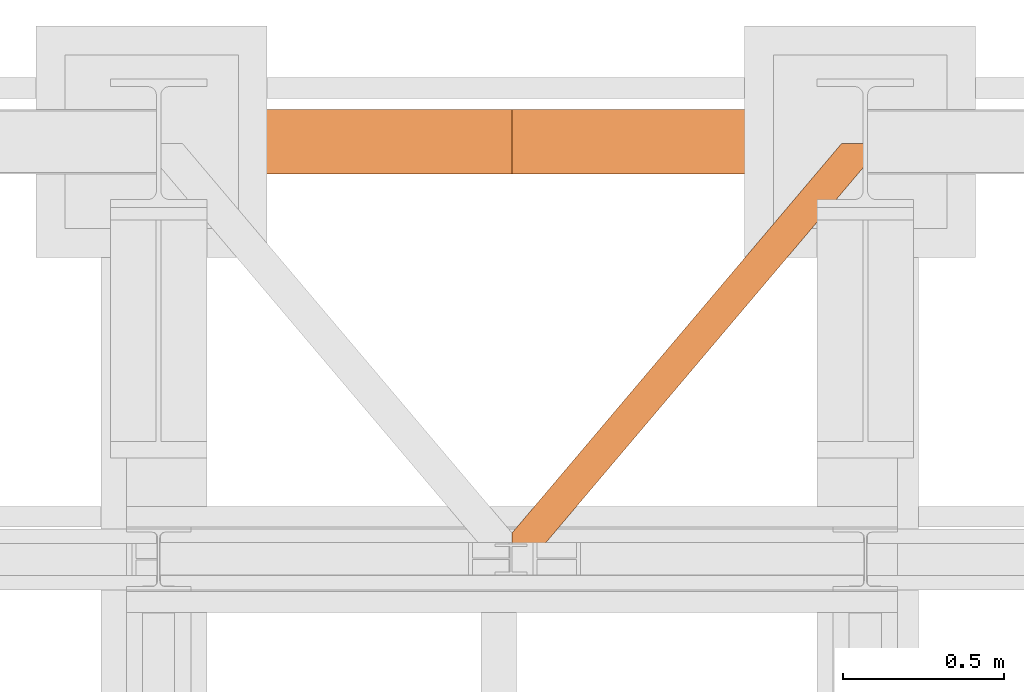
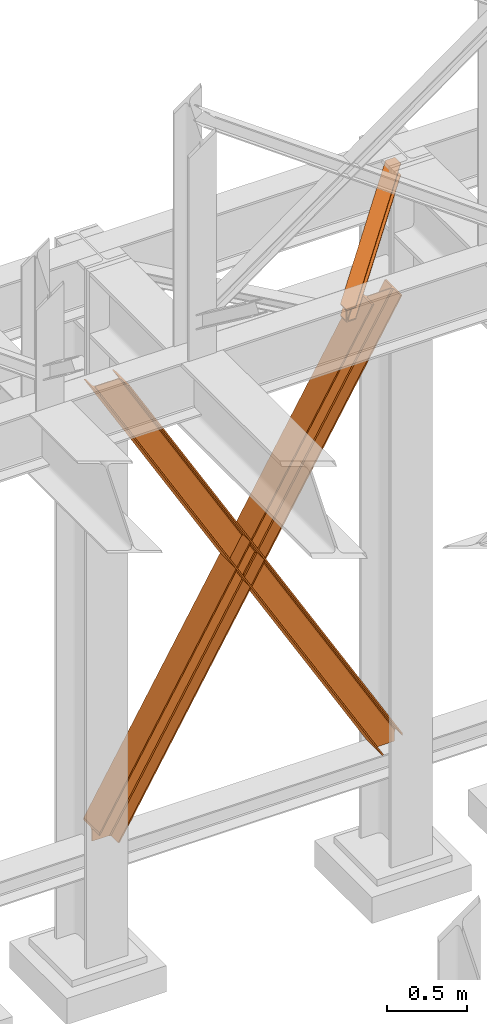
# One storey, part 140 of 208: 3 proxies.
"""IFC2X3 building model written with IfcOpenShell, lengths in millimetres."""

from ifc_helpers import new_model, entity, si_unit, converted_unit, frame, origin, origin_with_axes, place, context, subcontext, project, spatial, faceted_brep, element, save


model = new_model("IFC2X3")

# Units and contexts
model_context = context("Model", 3, precision=1e-05, world=origin())
plan_context = context("Plan", 3, precision=1e-05, world=origin())
body_context = subcontext(model_context, "Body", "Model", "MODEL_VIEW")
ifc_project = project(units=[si_unit("LENGTHUNIT", "METRE", prefix="MILLI"), converted_unit("PLANEANGLEUNIT", "DEGREE", entity("IfcPlaneAngleMeasure", 0.0174532925199433), si_unit("PLANEANGLEUNIT", "RADIAN"), dimensions=[0, 0, 0, 0, 0, 0, 0]), si_unit("AREAUNIT", "SQUARE_METRE"), si_unit("VOLUMEUNIT", "CUBIC_METRE")], contexts=[model_context, plan_context])

# Building, storey
building_placement = place(None, origin())
building = spatial("IfcBuilding", under=ifc_project, at=building_placement, CompositionType="COMPLEX")
storey_placement = place(building_placement, origin_with_axes())
storey = spatial("IfcBuildingStorey", under=building, at=storey_placement, Name="Geschoss", CompositionType="ELEMENT")

# Proxies
proxy_1_placement = place(storey_placement, frame((-0.1675494600947332, -12562.57439501764, 734.9900149335328), z_axis=(0.0, 0.0, 1.0), x_axis=(1.0, 0.0, 0.0)))
element("IfcBuildingElementProxy", 1, at=proxy_1_placement, inside=storey, context=body_context, shape_type="Brep", body=[
    faceted_brep([(2187.432517936612, 0.01000000000021828, 120.8497915510924), (216.8471928951319, 0.01000000000021828, 3468.009977913908), (216.8471928951319, 200.0100029802325, 3468.009977913908), (2187.432517936612, 200.0100029802325, 120.8497915510924), (2187.432517936612, 200.0100029802325, 120.8497915510924), (216.8471928951319, 200.0100029802325, 3468.009977913908), (205.4347121912165, 200.0100029802325, 3468.009977913908), (2187.432517936612, 200.0100029802325, 101.4682129393398), (2187.432517936612, 200.0100029802325, 101.4682129393398), (205.4347121912165, 200.0100029802325, 3468.009977913908), (205.4347036882539, 121.2600035762789, 3468.009977913908), (2187.432517936951, 121.2600035762789, 101.4681984983711), (2187.432517936951, 121.2600035762789, 101.4681984983711), (205.4347036882539, 121.2600035762789, 3468.009977913908), (203.3067948069668, 111.9441915473344, 3468.009977913909), (2187.432602958225, 111.9441915473344, 97.85427409430258), (2187.432602958225, 111.9441915473344, 97.85427409430258), (203.3067948069668, 111.9441915473344, 3468.009977913909), (195.5238886772497, 105.1245498640838, 3468.009977913908), (2187.432517936612, 105.1245498640838, 84.63689245399041), (2187.432517936612, 105.1245498640838, 84.63689245399041), (195.5238886772497, 105.1245498640838, 3468.009977913908), (184.892235020021, 103.2600015571716, 3468.009977913908), (2187.432517936612, 103.2600015571716, 66.58142866151923), (2187.432517936612, 103.2600015571716, 0.009999999999990905), (2187.432517936612, 103.2600015571716, 66.58142866151923), (184.892235020021, 103.2600015571716, 3468.009977913908), (31.96494937214834, 103.2600015571716, 3468.009977913908), (2073.723887154785, 103.2600015571716, 0.01000000000021828), (2073.723887154785, 103.2600015571716, 0.01000000000021828), (31.96494937214834, 103.2600015571716, 3468.009977913908), (21.3332957149189, 105.1245498640838, 3468.009977913908), (2063.093996904378, 105.1245498640838, 0.01000000000010459), (2063.093996904378, 105.1245498640838, 0.01000000000010459), (21.3332957149189, 105.1245498640838, 3468.009977913908), (13.55038958520231, 111.9441915473344, 3468.009977913908), (2055.312379673187, 111.9441915473344, 0.009999999999763531), (2055.312379673187, 111.9441915473344, 0.009999999999763531), (13.55038958520231, 111.9441915473344, 3468.009977913908), (11.42248070391565, 121.2600035762789, 3468.009977913907), (2053.184822892688, 121.2600035762789, 0.009999999999763531), (2053.184822892688, 121.2600035762789, 0.009999999999763531), (11.42248070391565, 121.2600035762789, 3468.009977913907), (11.42248070391611, 200.0100029802325, 3468.009977913907), (2053.184822892688, 200.0100029802325, 0.009999999999763531), (2053.184822892688, 200.0100029802325, 0.009999999999763531), (11.42248070391611, 200.0100029802325, 3468.009977913907), (0.009999999999990905, 200.0100029802325, 3468.009977913908), (2041.774228435658, 200.0100029802325, 0.009999999999990905), (2041.774228435658, 200.0100029802325, 0.009999999999990905), (0.009999999999990905, 200.0100029802325, 3468.009977913908), (0.009999999999990905, 0.01000000000021828, 3468.009977913908), (2041.774228435658, 0.01000000000021828, 0.009999999999990905), (2041.774228435658, 0.01000000000021828, 0.009999999999990905), (0.009999999999990905, 0.01000000000021828, 3468.009977913908), (11.42248070391656, 0.01000000000021828, 3468.009977913908), (2053.184822892688, 0.01000000000021828, 0.009999999999877218), (2053.184822892688, 0.01000000000021828, 0.009999999999877218), (11.42248070391656, 0.01000000000021828, 3468.009977913908), (11.42248070391611, 78.75999940395377, 3468.009977913907), (2053.184822892688, 78.75999940395377, 0.009999999999763531), (2053.184822892688, 78.75999940395377, 0.009999999999763531), (11.42248070391611, 78.75999940395377, 3468.009977913907), (13.55038958520231, 88.07581143290008, 3468.009977913908), (2055.312379673187, 88.07581143289826, 0.009999999999763531), (2055.312379673187, 88.07581143289826, 0.009999999999763531), (13.55038958520231, 88.07581143290008, 3468.009977913908), (21.3332957149189, 94.89545311614893, 3468.009977913908), (2063.093996904378, 94.89545311614893, 0.009999999999763531), (2063.093996904378, 94.89545311614893, 0.009999999999763531), (21.3332957149189, 94.89545311614893, 3468.009977913908), (31.96494937214834, 96.76000142306111, 3468.009977913908), (2073.723887154785, 96.76000142306111, 0.01000000000021828), (2073.723887154785, 96.76000142306111, 0.01000000000021828), (31.96494937214834, 96.76000142306111, 3468.009977913908), (184.892235020021, 96.76000142306111, 3468.009977913908), (2187.432517936612, 96.76000142306111, 66.58142866151888), (2187.432517936612, 96.76000142306111, 0.009999999999990905), (2187.432517936612, 96.76000142306111, 66.58142866151888), (184.892235020021, 96.76000142306111, 3468.009977913908), (195.5238886772497, 94.89545311614893, 3468.009977913908), (2187.432517936612, 94.89545311615075, 84.63689245399041), (2187.432517936612, 94.89545311615075, 84.63689245399041), (195.5238886772497, 94.89545311614893, 3468.009977913908), (203.3067948069668, 88.07581143289826, 3468.009977913909), (2187.432517936612, 88.07581143289826, 97.85441850857092), (2187.432517936612, 88.07581143289826, 97.85441850857092), (203.3067948069668, 88.07581143289826, 3468.009977913909), (205.4347036882541, 78.75999940395377, 3468.009977913908), (2187.432433072335, 78.75999940395377, 101.4683426459951), (2187.432433072335, 78.75999940395377, 101.4683426459951), (205.4347036882541, 78.75999940395377, 3468.009977913908), (205.4347121912165, 0.01000000000021828, 3468.009977913908), (2187.432517936272, 0.01000000000021828, 101.4682129399164), (2187.432517936272, 0.01000000000021828, 101.4682129399164), (205.4347121912165, 0.01000000000021828, 3468.009977913908), (216.8471928951319, 0.01000000000021828, 3468.009977913908), (2187.432517936612, 0.01000000000021828, 120.8497915510924), (216.8471928951319, 0.01000000000021828, 3468.009977913908), (205.4347121912165, 0.01000000000021828, 3468.009977913908), (205.4347036882541, 78.75999940395377, 3468.009977913908), (203.3067948069668, 88.07581143289826, 3468.009977913909), (195.5238886772497, 94.89545311614893, 3468.009977913908), (184.892235020021, 96.76000142306111, 3468.009977913908), (31.96494937214834, 96.76000142306111, 3468.009977913908), (21.3332957149189, 94.89545311614893, 3468.009977913908), (13.55038958520231, 88.07581143290008, 3468.009977913908), (11.42248070391611, 78.75999940395377, 3468.009977913907), (11.42248070391656, 0.01000000000021828, 3468.009977913908), (0.009999999999990905, 0.01000000000021828, 3468.009977913908), (0.009999999999990905, 200.0100029802325, 3468.009977913908), (11.42248070391611, 200.0100029802325, 3468.009977913907), (11.42248070391565, 121.2600035762789, 3468.009977913907), (13.55038958520231, 111.9441915473344, 3468.009977913908), (21.3332957149189, 105.1245498640838, 3468.009977913908), (31.96494937214834, 103.2600015571716, 3468.009977913908), (184.892235020021, 103.2600015571716, 3468.009977913908), (195.5238886772497, 105.1245498640838, 3468.009977913908), (203.3067948069668, 111.9441915473344, 3468.009977913909), (205.4347036882539, 121.2600035762789, 3468.009977913908), (205.4347121912165, 200.0100029802325, 3468.009977913908), (216.8471928951319, 200.0100029802325, 3468.009977913908), (2187.432517936612, 96.76000142306111, 0.009999999999990905), (2187.432517936612, 96.76000142306111, 66.58142866151888), (2187.432517936612, 94.89545311615075, 84.63689245399041), (2187.432517936612, 88.07581143289826, 97.85441850857092), (2187.432433072335, 78.75999940395377, 101.4683426459951), (2187.432517936272, 0.01000000000021828, 101.4682129399164), (2187.432517936612, 0.01000000000021828, 120.8497915510924), (2187.432517936612, 200.0100029802325, 120.8497915510924), (2187.432517936612, 200.0100029802325, 101.4682129393398), (2187.432517936951, 121.2600035762789, 101.4681984983711), (2187.432602958225, 111.9441915473344, 97.85427409430258), (2187.432517936612, 105.1245498640838, 84.63689245399041), (2187.432517936612, 103.2600015571716, 66.58142866151923), (2187.432517936612, 103.2600015571716, 0.009999999999990905), (2073.723887154785, 103.2600015571716, 0.01000000000021828), (2063.093996904378, 105.1245498640838, 0.01000000000010459), (2055.312379673187, 111.9441915473344, 0.009999999999763531), (2053.184822892688, 121.2600035762789, 0.009999999999763531), (2053.184822892688, 200.0100029802325, 0.009999999999763531), (2041.774228435658, 200.0100029802325, 0.009999999999990905), (2041.774228435658, 0.01000000000021828, 0.009999999999990905), (2053.184822892688, 0.01000000000021828, 0.009999999999877218), (2053.184822892688, 78.75999940395377, 0.009999999999763531), (2055.312379673187, 88.07581143289826, 0.009999999999763531), (2063.093996904378, 94.89545311614893, 0.009999999999763531), (2073.723887154785, 96.76000142306111, 0.01000000000021828), (2187.432517936612, 96.76000142306111, 0.009999999999990905), (2187.432517936612, 103.2600015571716, 0.009999999999990905)], [[[0, 1, 2, 3]], [[4, 5, 6, 7]], [[8, 9, 10, 11]], [[12, 13, 14, 15]], [[16, 17, 18, 19]], [[20, 21, 22, 23]], [[24, 25, 26, 27, 28]], [[29, 30, 31, 32]], [[33, 34, 35, 36]], [[37, 38, 39, 40]], [[41, 42, 43, 44]], [[45, 46, 47, 48]], [[49, 50, 51, 52]], [[53, 54, 55, 56]], [[57, 58, 59, 60]], [[61, 62, 63, 64]], [[65, 66, 67, 68]], [[69, 70, 71, 72]], [[73, 74, 75, 76, 77]], [[78, 79, 80, 81]], [[82, 83, 84, 85]], [[86, 87, 88, 89]], [[90, 91, 92, 93]], [[94, 95, 96, 97]], [[98, 99, 100, 101, 102, 103, 104, 105, 106, 107, 108, 109, 110, 111, 112, 113, 114, 115, 116, 117, 118, 119, 120, 121]], [[122, 123, 124, 125, 126, 127, 128, 129, 130, 131, 132, 133, 134, 135]], [[136, 137, 138, 139, 140, 141, 142, 143, 144, 145, 146, 147, 148, 149]]], orient=[[False], [False], [False], [False], [False], [False], [False], [False], [False], [False], [False], [False], [False], [False], [False], [False], [False], [False], [False], [False], [False], [False], [False], [False], [False], [False], [False]]),
])
proxy_2_placement = place(storey_placement, frame((-0.7451164407873421, -12562.57439501764, 734.9900149335328), z_axis=(0.0, 0.0, 1.0), x_axis=(1.0, 0.0, 0.0)))
element("IfcBuildingElementProxy", 2, at=proxy_2_placement, inside=storey, context=body_context, shape_type="Brep", body=[
    faceted_brep([(0.0100850216138042, 0.01000000000021828, 120.8497915510924), (0.0100850216138042, 200.0100029802325, 120.8497915510924), (1970.595410063094, 200.0100029802325, 3468.009977913908), (1970.595410063094, 0.01000000000021828, 3468.009977913908), (0.0100850216138042, 200.0100029802325, 120.8497915510924), (0.01008502161334945, 200.0100029802325, 101.4682129393398), (1982.007890767009, 200.0100029802325, 3468.009977913908), (1970.595410063094, 200.0100029802325, 3468.009977913908), (0.01008502161334945, 200.0100029802325, 101.4682129393398), (0.01008502127456268, 121.2600035762789, 101.4681984983711), (1982.007899269972, 121.2600035762789, 3468.009977913908), (1982.007890767009, 200.0100029802325, 3468.009977913908), (0.01008502127456268, 121.2600035762789, 101.4681984983711), (0.009999999999990905, 111.9441915473344, 97.85427409430258), (1984.135808151259, 111.9441915473344, 3468.009977913909), (1982.007899269972, 121.2600035762789, 3468.009977913908), (0.009999999999990905, 111.9441915473344, 97.85427409430258), (0.0100850216138042, 105.1245498640838, 84.63689245399041), (1991.918714280976, 105.1245498640838, 3468.009977913908), (1984.135808151259, 111.9441915473344, 3468.009977913909), (0.0100850216138042, 105.1245498640838, 84.63689245399041), (0.0100850216138042, 103.2600015571716, 66.58142866151923), (2002.550367938205, 103.2600015571716, 3468.009977913908), (1991.918714280976, 105.1245498640838, 3468.009977913908), (0.0100850216138042, 103.2600015571716, 0.009999999999990905), (113.7187158034401, 103.2600015571716, 0.01000000000021828), (2155.477653586077, 103.2600015571716, 3468.009977913908), (2002.550367938205, 103.2600015571716, 3468.009977913908), (0.0100850216138042, 103.2600015571716, 66.58142866151923), (113.7187158034401, 103.2600015571716, 0.01000000000021828), (124.3486060538469, 105.1245498640838, 0.01000000000010459), (2166.109307243306, 105.1245498640838, 3468.009977913908), (2155.477653586077, 103.2600015571716, 3468.009977913908), (124.3486060538469, 105.1245498640838, 0.01000000000010459), (132.1302232850383, 111.9441915473344, 0.009999999999763531), (2173.892213373023, 111.9441915473344, 3468.009977913908), (2166.109307243306, 105.1245498640838, 3468.009977913908), (132.1302232850383, 111.9441915473344, 0.009999999999763531), (134.257780065537, 121.2600035762789, 0.009999999999763531), (2176.020122254309, 121.2600035762789, 3468.009977913907), (2173.892213373023, 111.9441915473344, 3468.009977913908), (134.257780065537, 121.2600035762789, 0.009999999999763531), (134.257780065537, 200.0100029802325, 0.009999999999763531), (2176.020122254309, 200.0100029802325, 3468.009977913907), (2176.020122254309, 121.2600035762789, 3468.009977913907), (134.257780065537, 200.0100029802325, 0.009999999999763531), (145.6683745225666, 200.0100029802325, 0.009999999999990905), (2187.432602958225, 200.0100029802325, 3468.009977913908), (2176.020122254309, 200.0100029802325, 3468.009977913907), (145.6683745225666, 200.0100029802325, 0.009999999999990905), (145.6683745225666, 0.01000000000021828, 0.009999999999990905), (2187.432602958225, 0.01000000000021828, 3468.009977913908), (2187.432602958225, 200.0100029802325, 3468.009977913908), (145.6683745225666, 0.01000000000021828, 0.009999999999990905), (134.257780065537, 0.01000000000021828, 0.009999999999877218), (2176.020122254308, 0.01000000000021828, 3468.009977913908), (2187.432602958225, 0.01000000000021828, 3468.009977913908), (134.257780065537, 0.01000000000021828, 0.009999999999877218), (134.257780065537, 78.75999940395377, 0.009999999999763531), (2176.020122254309, 78.75999940395377, 3468.009977913907), (2176.020122254308, 0.01000000000021828, 3468.009977913908), (134.257780065537, 78.75999940395377, 0.009999999999763531), (132.1302232850383, 88.07581143289826, 0.009999999999763531), (2173.892213373023, 88.07581143290008, 3468.009977913908), (2176.020122254309, 78.75999940395377, 3468.009977913907), (132.1302232850383, 88.07581143289826, 0.009999999999763531), (124.3486060538464, 94.89545311614893, 0.009999999999763531), (2166.109307243306, 94.89545311614893, 3468.009977913908), (2173.892213373023, 88.07581143290008, 3468.009977913908), (124.3486060538464, 94.89545311614893, 0.009999999999763531), (113.7187158034401, 96.76000142306111, 0.01000000000021828), (2155.477653586077, 96.76000142306111, 3468.009977913908), (2166.109307243306, 94.89545311614893, 3468.009977913908), (113.7187158034401, 96.76000142306111, 0.01000000000021828), (0.01008502161334945, 96.76000142306111, 0.009999999999990905), (0.0100850216138042, 96.76000142306111, 66.58142866151888), (2002.550367938205, 96.76000142306111, 3468.009977913908), (2155.477653586077, 96.76000142306111, 3468.009977913908), (0.0100850216138042, 96.76000142306111, 66.58142866151888), (0.0100850216138042, 94.89545311615075, 84.63689245399041), (1991.918714280976, 94.89545311614893, 3468.009977913908), (2002.550367938205, 96.76000142306111, 3468.009977913908), (0.0100850216138042, 94.89545311615075, 84.63689245399041), (0.0100850216138042, 88.07581143289826, 97.85441850857092), (1984.135808151259, 88.07581143289826, 3468.009977913909), (1991.918714280976, 94.89545311614893, 3468.009977913908), (0.0100850216138042, 88.07581143289826, 97.85441850857092), (0.01016988589049106, 78.75999940395377, 101.4683426459951), (1982.007899269971, 78.75999940395377, 3468.009977913908), (1984.135808151259, 88.07581143289826, 3468.009977913909), (0.01016988589049106, 78.75999940395377, 101.4683426459951), (0.01008502195304573, 0.01000000000021828, 101.4682129399164), (1982.007890767009, 0.01000000000021828, 3468.009977913908), (1982.007899269971, 78.75999940395377, 3468.009977913908), (0.01008502195304573, 0.01000000000021828, 101.4682129399164), (0.0100850216138042, 0.01000000000021828, 120.8497915510924), (1970.595410063094, 0.01000000000021828, 3468.009977913908), (1982.007890767009, 0.01000000000021828, 3468.009977913908), (1970.595410063094, 0.01000000000021828, 3468.009977913908), (1970.595410063094, 200.0100029802325, 3468.009977913908), (1982.007890767009, 200.0100029802325, 3468.009977913908), (1982.007899269972, 121.2600035762789, 3468.009977913908), (1984.135808151259, 111.9441915473344, 3468.009977913909), (1991.918714280976, 105.1245498640838, 3468.009977913908), (2002.550367938205, 103.2600015571716, 3468.009977913908), (2155.477653586077, 103.2600015571716, 3468.009977913908), (2166.109307243306, 105.1245498640838, 3468.009977913908), (2173.892213373023, 111.9441915473344, 3468.009977913908), (2176.020122254309, 121.2600035762789, 3468.009977913907), (2176.020122254309, 200.0100029802325, 3468.009977913907), (2187.432602958225, 200.0100029802325, 3468.009977913908), (2187.432602958225, 0.01000000000021828, 3468.009977913908), (2176.020122254308, 0.01000000000021828, 3468.009977913908), (2176.020122254309, 78.75999940395377, 3468.009977913907), (2173.892213373023, 88.07581143290008, 3468.009977913908), (2166.109307243306, 94.89545311614893, 3468.009977913908), (2155.477653586077, 96.76000142306111, 3468.009977913908), (2002.550367938205, 96.76000142306111, 3468.009977913908), (1991.918714280976, 94.89545311614893, 3468.009977913908), (1984.135808151259, 88.07581143289826, 3468.009977913909), (1982.007899269971, 78.75999940395377, 3468.009977913908), (1982.007890767009, 0.01000000000021828, 3468.009977913908), (0.01008502161334945, 96.76000142306111, 0.009999999999990905), (0.0100850216138042, 103.2600015571716, 0.009999999999990905), (0.0100850216138042, 103.2600015571716, 66.58142866151923), (0.0100850216138042, 105.1245498640838, 84.63689245399041), (0.009999999999990905, 111.9441915473344, 97.85427409430258), (0.01008502127456268, 121.2600035762789, 101.4681984983711), (0.01008502161334945, 200.0100029802325, 101.4682129393398), (0.0100850216138042, 200.0100029802325, 120.8497915510924), (0.0100850216138042, 0.01000000000021828, 120.8497915510924), (0.01008502195304573, 0.01000000000021828, 101.4682129399164), (0.01016988589049106, 78.75999940395377, 101.4683426459951), (0.0100850216138042, 88.07581143289826, 97.85441850857092), (0.0100850216138042, 94.89545311615075, 84.63689245399041), (0.0100850216138042, 96.76000142306111, 66.58142866151888), (113.7187158034401, 103.2600015571716, 0.01000000000021828), (0.0100850216138042, 103.2600015571716, 0.009999999999990905), (0.01008502161334945, 96.76000142306111, 0.009999999999990905), (113.7187158034401, 96.76000142306111, 0.01000000000021828), (124.3486060538464, 94.89545311614893, 0.009999999999763531), (132.1302232850383, 88.07581143289826, 0.009999999999763531), (134.257780065537, 78.75999940395377, 0.009999999999763531), (134.257780065537, 0.01000000000021828, 0.009999999999877218), (145.6683745225666, 0.01000000000021828, 0.009999999999990905), (145.6683745225666, 200.0100029802325, 0.009999999999990905), (134.257780065537, 200.0100029802325, 0.009999999999763531), (134.257780065537, 121.2600035762789, 0.009999999999763531), (132.1302232850383, 111.9441915473344, 0.009999999999763531), (124.3486060538469, 105.1245498640838, 0.01000000000010459)], [[[0, 1, 2, 3]], [[4, 5, 6, 7]], [[8, 9, 10, 11]], [[12, 13, 14, 15]], [[16, 17, 18, 19]], [[20, 21, 22, 23]], [[24, 25, 26, 27, 28]], [[29, 30, 31, 32]], [[33, 34, 35, 36]], [[37, 38, 39, 40]], [[41, 42, 43, 44]], [[45, 46, 47, 48]], [[49, 50, 51, 52]], [[53, 54, 55, 56]], [[57, 58, 59, 60]], [[61, 62, 63, 64]], [[65, 66, 67, 68]], [[69, 70, 71, 72]], [[73, 74, 75, 76, 77]], [[78, 79, 80, 81]], [[82, 83, 84, 85]], [[86, 87, 88, 89]], [[90, 91, 92, 93]], [[94, 95, 96, 97]], [[98, 99, 100, 101, 102, 103, 104, 105, 106, 107, 108, 109, 110, 111, 112, 113, 114, 115, 116, 117, 118, 119, 120, 121]], [[122, 123, 124, 125, 126, 127, 128, 129, 130, 131, 132, 133, 134, 135]], [[136, 137, 138, 139, 140, 141, 142, 143, 144, 145, 146, 147, 148, 149]]], orient=[[False], [False], [False], [False], [False], [False], [False], [False], [False], [False], [False], [False], [False], [False], [False], [False], [False], [False], [False], [False], [False], [False], [False], [False], [False], [False], [False]]),
])
proxy_3_placement = place(storey_placement, frame((1093.254968528672, -13757.87439038569, 5101.99001616488), z_axis=(0.0, 0.0, 1.0), x_axis=(1.0, 0.0, 0.0)))
element("IfcBuildingElementProxy", 3, at=proxy_3_placement, inside=storey, context=body_context, shape_type="Brep", body=[
    faceted_brep([(65.50764084493926, 0.00999999999839929, 8.010001311303313), (1094.009999947835, 1215.512788030694, 8.010001311302403), (1094.009999947835, 1215.512788030694, 0.01000000000112777), (65.50764084493926, 0.00999999999839929, 0.01000000000112777), (65.50764084493926, 0.00999999999839929, 0.01000000000112777), (1094.009999947835, 1215.512788030694, 0.01000000000112777), (1094.009999947835, 1290.610003345229, 0.01000000000021828), (1026.558515831797, 1290.610003345229, 0.01000000000021828), (0.01000000000271939, 77.41630281674588, 0.01000000000112777), (0.01000000000271939, 0.00999999999839929, 0.01000000000112777), (0.01000000000271939, 77.41630281674588, 0.01000000000112777), (1026.558515831797, 1290.610003345229, 0.01000000000021828), (1026.558515831797, 1290.610003345229, 8.010001311303313), (0.0100000000009004, 77.41630281674406, 8.010001311303313), (0.0100000000009004, 77.41630281674406, 8.010001311303313), (1026.558515831797, 1290.610003345229, 8.010001311303313), (1073.061840441307, 1290.610003345229, 8.010001311303313), (0.01000000000271939, 22.45782827823314, 8.010001311303313), (0.01000000000271939, 22.45782827823314, 8.010001311303313), (1073.061840441307, 1290.610003345229, 8.010001311303313), (1081.197355239432, 1290.610003345229, 9.253033826352294), (0.01000000000180989, 12.84312897135897, 9.253033826352294), (0.01000000000180989, 12.84312897135897, 9.253033826352294), (1081.197355239432, 1290.610003345229, 9.253033826352294), (1087.152961141162, 1290.610003345229, 13.79946006298178), (0.01000000000180989, 5.804685632949258, 13.79946006298178), (0.01000000000180989, 5.804685632949258, 13.79946006298178), (1087.152961141162, 1290.610003345229, 13.79946006298178), (1088.781274451488, 1290.610003345229, 20.01000141561144), (0.01000000000271939, 3.880315357109794, 20.01000141561144), (0.01000000000271939, 3.880315357109794, 20.01000141561144), (1088.781274451488, 1290.610003345229, 20.01000141561144), (1088.781274451488, 1290.610003345229, 76.01000128150099), (0.01000000000271939, 3.880315357109794, 76.01000128150099), (0.01000000000271939, 3.880315357109794, 76.01000128150099), (1088.781274451488, 1290.610003345229, 76.01000128150099), (1087.152961141161, 1290.610003345229, 82.2205407714855), (0.01000000000180989, 5.804685632949258, 82.2205407714855), (0.01000000000180989, 5.804685632949258, 82.2205407714855), (1087.152961141161, 1290.610003345229, 82.2205407714855), (1081.197355239431, 1290.610003345229, 86.76696700811499), (0.01000000000180989, 12.84312897135897, 86.76696700811499), (0.01000000000180989, 12.84312897135897, 86.76696700811499), (1081.197355239431, 1290.610003345229, 86.76696700811499), (1073.061840441306, 1290.610003345229, 88.00999952316397), (0.01000000000180989, 22.45782827823314, 88.00999952316397), (0.01000000000180989, 22.45782827823314, 88.00999952316397), (1073.061840441306, 1290.610003345229, 88.00999952316397), (1026.558515831797, 1290.610003345229, 88.00999952316397), (0.01000000000271939, 77.41630281674588, 88.00999952316397), (0.01000000000271939, 77.41630281674588, 88.00999952316397), (1026.558515831797, 1290.610003345229, 88.00999952316397), (1026.558515831797, 1290.610003345229, 96.01000083446615), (0.009999999999990905, 77.41630281674406, 96.01000083446615), (0.009999999999990905, 77.41630281674406, 96.01000083446615), (1026.558515831797, 1290.610003345229, 96.01000083446615), (1094.009999947835, 1290.610003345229, 96.01000083446615), (1094.009999947835, 1215.512788030694, 96.01000083446615), (65.50764084493835, 0.00999999999839929, 96.01000083446615), (0.0100000000009004, 0.00999999999839929, 96.01000083446615), (65.50764084493835, 0.00999999999839929, 96.01000083446615), (1094.009999947835, 1215.512788030694, 96.01000083446615), (1094.009999947835, 1215.512788030694, 88.00999952316397), (65.50764084493835, 0.00999999999839929, 88.00999952316397), (65.50764084493835, 0.00999999999839929, 88.00999952316397), (1094.009999947835, 1215.512788030694, 88.00999952316397), (1094.009999947835, 1270.471262569206, 88.00999952316397), (19.0043162354275, 0.00999999999839929, 88.00999952316397), (19.0043162354275, 0.00999999999839929, 88.00999952316397), (1094.009999947835, 1270.471262569206, 88.00999952316397), (1094.009999947835, 1280.085961876082, 86.76696700811499), (10.86880143730173, 0.00999999999839929, 86.76696700811499), (10.86880143730173, 0.00999999999839929, 86.76696700811499), (1094.009999947835, 1280.085961876082, 86.76696700811499), (1094.009999947835, 1287.124405214488, 82.2205407714855), (4.913195535572186, 0.00999999999839929, 82.2205407714855), (4.913195535572186, 0.00999999999839929, 82.2205407714855), (1094.009999947835, 1287.124405214488, 82.2205407714855), (1094.009999947834, 1289.048775490332, 76.01000128150099), (3.284882225245156, 0.00999999999839929, 76.01000128150099), (3.284882225245156, 0.00999999999839929, 76.01000128150099), (1094.009999947834, 1289.048775490332, 76.01000128150099), (1094.009999947835, 1289.048775490332, 20.01000141561144), (3.284882225246065, 0.00999999999839929, 20.01000141561144), (3.284882225246065, 0.00999999999839929, 20.01000141561144), (1094.009999947835, 1289.048775490332, 20.01000141561144), (1094.009999947835, 1287.12440521449, 13.79946006298178), (4.913195535572186, 0.00999999999839929, 13.79946006298178), (4.913195535572186, 0.00999999999839929, 13.79946006298178), (1094.009999947835, 1287.12440521449, 13.79946006298178), (1094.009999947835, 1280.085961876081, 9.253033826352294), (10.86880143730264, 0.00999999999839929, 9.253033826352294), (10.86880143730264, 0.00999999999839929, 9.253033826352294), (1094.009999947835, 1280.085961876081, 9.253033826352294), (1094.009999947835, 1270.471262569206, 8.010001311303313), (19.00431623542931, 0.00999999999839929, 8.010001311303313), (19.00431623542931, 0.00999999999839929, 8.010001311303313), (1094.009999947835, 1270.471262569206, 8.010001311303313), (1094.009999947835, 1215.512788030694, 8.010001311302403), (65.50764084493926, 0.00999999999839929, 8.010001311303313), (0.01000000000271939, 77.41630281674588, 0.01000000000112777), (0.0100000000009004, 77.41630281674406, 8.010001311303313), (0.01000000000271939, 22.45782827823314, 8.010001311303313), (0.01000000000180989, 12.84312897135897, 9.253033826352294), (0.01000000000180989, 5.804685632949258, 13.79946006298178), (0.01000000000271939, 3.880315357109794, 20.01000141561144), (0.01000000000271939, 3.880315357109794, 76.01000128150099), (0.01000000000180989, 5.804685632949258, 82.2205407714855), (0.01000000000180989, 12.84312897135897, 86.76696700811499), (0.01000000000180989, 22.45782827823314, 88.00999952316397), (0.01000000000271939, 77.41630281674588, 88.00999952316397), (0.009999999999990905, 77.41630281674406, 96.01000083446615), (0.0100000000009004, 0.00999999999839929, 96.01000083446615), (0.01000000000271939, 0.00999999999839929, 0.01000000000112777), (0.0100000000009004, 0.00999999999839929, 96.01000083446615), (65.50764084493835, 0.00999999999839929, 96.01000083446615), (65.50764084493835, 0.00999999999839929, 88.00999952316397), (19.0043162354275, 0.00999999999839929, 88.00999952316397), (10.86880143730173, 0.00999999999839929, 86.76696700811499), (4.913195535572186, 0.00999999999839929, 82.2205407714855), (3.284882225245156, 0.00999999999839929, 76.01000128150099), (3.284882225246065, 0.00999999999839929, 20.01000141561144), (4.913195535572186, 0.00999999999839929, 13.79946006298178), (10.86880143730264, 0.00999999999839929, 9.253033826352294), (19.00431623542931, 0.00999999999839929, 8.010001311303313), (65.50764084493926, 0.00999999999839929, 8.010001311303313), (65.50764084493926, 0.00999999999839929, 0.01000000000112777), (0.01000000000271939, 0.00999999999839929, 0.01000000000112777), (1094.009999947835, 1215.512788030694, 8.010001311302403), (1094.009999947835, 1270.471262569206, 8.010001311303313), (1094.009999947835, 1280.085961876081, 9.253033826352294), (1094.009999947835, 1287.12440521449, 13.79946006298178), (1094.009999947835, 1289.048775490332, 20.01000141561144), (1094.009999947834, 1289.048775490332, 76.01000128150099), (1094.009999947835, 1287.124405214488, 82.2205407714855), (1094.009999947835, 1280.085961876082, 86.76696700811499), (1094.009999947835, 1270.471262569206, 88.00999952316397), (1094.009999947835, 1215.512788030694, 88.00999952316397), (1094.009999947835, 1215.512788030694, 96.01000083446615), (1094.009999947835, 1290.610003345229, 96.01000083446615), (1094.009999947835, 1290.610003345229, 0.01000000000021828), (1094.009999947835, 1215.512788030694, 0.01000000000112777), (1094.009999947835, 1290.610003345229, 0.01000000000021828), (1094.009999947835, 1290.610003345229, 96.01000083446615), (1026.558515831797, 1290.610003345229, 96.01000083446615), (1026.558515831797, 1290.610003345229, 88.00999952316397), (1073.061840441306, 1290.610003345229, 88.00999952316397), (1081.197355239431, 1290.610003345229, 86.76696700811499), (1087.152961141161, 1290.610003345229, 82.2205407714855), (1088.781274451488, 1290.610003345229, 76.01000128150099), (1088.781274451488, 1290.610003345229, 20.01000141561144), (1087.152961141162, 1290.610003345229, 13.79946006298178), (1081.197355239432, 1290.610003345229, 9.253033826352294), (1073.061840441307, 1290.610003345229, 8.010001311303313), (1026.558515831797, 1290.610003345229, 8.010001311303313), (1026.558515831797, 1290.610003345229, 0.01000000000021828)], [[[0, 1, 2, 3]], [[4, 5, 6, 7, 8, 9]], [[10, 11, 12, 13]], [[14, 15, 16, 17]], [[18, 19, 20, 21]], [[22, 23, 24, 25]], [[26, 27, 28, 29]], [[30, 31, 32, 33]], [[34, 35, 36, 37]], [[38, 39, 40, 41]], [[42, 43, 44, 45]], [[46, 47, 48, 49]], [[50, 51, 52, 53]], [[54, 55, 56, 57, 58, 59]], [[60, 61, 62, 63]], [[64, 65, 66, 67]], [[68, 69, 70, 71]], [[72, 73, 74, 75]], [[76, 77, 78, 79]], [[80, 81, 82, 83]], [[84, 85, 86, 87]], [[88, 89, 90, 91]], [[92, 93, 94, 95]], [[96, 97, 98, 99]], [[100, 101, 102, 103, 104, 105, 106, 107, 108, 109, 110, 111, 112, 113]], [[114, 115, 116, 117, 118, 119, 120, 121, 122, 123, 124, 125, 126, 127]], [[128, 129, 130, 131, 132, 133, 134, 135, 136, 137, 138, 139, 140, 141]], [[142, 143, 144, 145, 146, 147, 148, 149, 150, 151, 152, 153, 154, 155]]], orient=[[False], [False], [False], [False], [False], [False], [False], [False], [False], [False], [False], [False], [False], [False], [False], [False], [False], [False], [False], [False], [False], [False], [False], [False], [False], [False], [False], [False]]),
])

save(model, "model.ifc")
